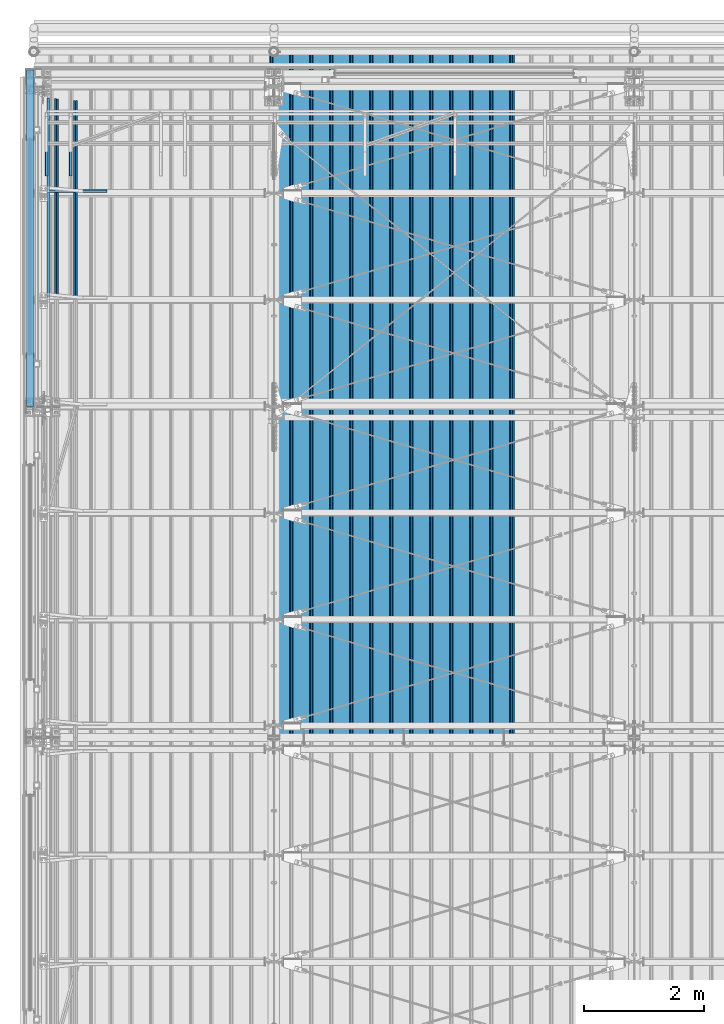
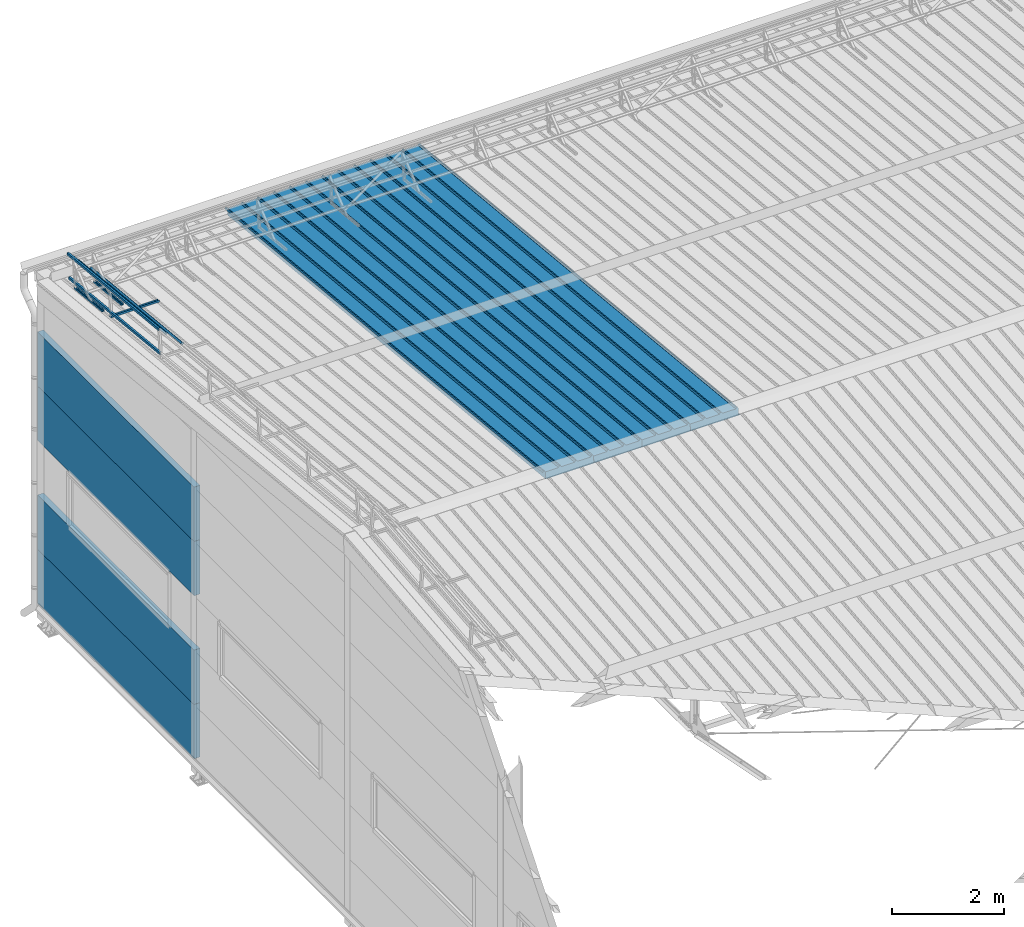
# One storey, part 50 of 709: 15 beams, 15 elements without a shape of their own.
"""IFC4 building model written with IfcOpenShell, lengths in millimetres."""

from ifc_helpers import new_model, si_unit, direction, frame, origin_with_axes, place, context, subcontext, project, spatial, line, indexed_curve, outline, extrude, material, element, aggregate, save


model = new_model("IFC4")

# Units and contexts
model_context = context("Model", 3, precision=0.2, world=origin_with_axes(), true_north=direction((0.0, 1.0)))
body_context = subcontext(model_context, "Body", "Model", "MODEL_VIEW")
ifc_project = project(units=[si_unit("LENGTHUNIT", "METRE", prefix="MILLI"), si_unit("AREAUNIT", "SQUARE_METRE"), si_unit("VOLUMEUNIT", "CUBIC_METRE"), si_unit("MASSUNIT", "GRAM", prefix="KILO"), si_unit("TIMEUNIT", "SECOND"), si_unit("PLANEANGLEUNIT", "RADIAN"), si_unit("SOLIDANGLEUNIT", "STERADIAN"), si_unit("THERMODYNAMICTEMPERATUREUNIT", "DEGREE_CELSIUS"), si_unit("LUMINOUSINTENSITYUNIT", "LUMEN")], contexts=[model_context])

# Site, building, storey
site_placement = place(None, origin_with_axes())
site = spatial("IfcSite", under=ifc_project, at=site_placement, CompositionType="ELEMENT")
building_placement = place(site_placement, origin_with_axes())
building = spatial("IfcBuilding", under=site, at=building_placement, Name="Undefined", CompositionType="ELEMENT")
storey_placement = place(building_placement, origin_with_axes())
storey = spatial("IfcBuildingStorey", under=building, at=storey_placement, Name="Undefined", CompositionType="ELEMENT", Elevation=0.0)

# Assembly, beam
assembly_1_placement = place(storey_placement, frame((7452.44, 11009.10459, 8419.96887), z_axis=(1.0, 0.0, 0.0), x_axis=(0.0, 0.9950371902, -0.099503719)))
assembly_1 = element("IfcElementAssembly", 1, at=assembly_1_placement, inside=storey)
ifc_material_1 = material(Name="Insulation", Category="Insulation")
beam_1_placement = place(assembly_1_placement, origin_with_axes())
beam_1 = element("IfcBeam", 2, at=beam_1_placement, material=ifc_material_1, ObjectType="P-99", context=body_context, shape_type="SolidModel", body=[
    extrude(outline(indexed_curve([(-509.8453, 89.5), (-490.1547, 89.5), (-471.67949, 57.5), (-471.67949, -88.5), (-436.67949, -88.5), (-436.67949, -91.5), (562.55841, -91.5), (562.55841, -89.5), (527.55841, -89.5), (527.55841, 57.5), (510.2379, 88.5), (489.7621, 88.5), (472.44159, 58.5), (196.71923, 58.5), (177.66667, 91.5), (155.66667, 91.5), (136.61411, 58.5), (-136.61411, 58.5), (-155.66667, 91.5), (-177.66667, 91.5), (-196.71923, 58.5), (-469.94744, 58.5), (-489.0, 91.5), (-511.0, 91.5), (-527.16581, 63.5), (-525.43376, 62.5)], segments=[line(1, 2, 3, 4, 5, 6, 7, 8, 9, 10, 11, 12, 13, 14, 15, 16, 17, 18, 19, 20, 21, 22, 23, 24, 25, 26, 1)])), frame((0.0, 0.0, 0.0), z_axis=(-1.0, 0.0, 0.0), x_axis=(0.0, 0.0, 1.0)), (0.0, 0.0, -1.0), 11459.0),
])
aggregate(assembly_1, [beam_1])

assembly_2_placement = place(storey_placement, frame((6452.44, 11009.10459, 8419.96887), z_axis=(1.0, 0.0, 0.0), x_axis=(0.0, 0.9950371902, -0.099503719)))
assembly_2 = element("IfcElementAssembly", 3, at=assembly_2_placement, inside=storey)
beam_2_placement = place(assembly_2_placement, origin_with_axes())
beam_2 = element("IfcBeam", 4, at=beam_2_placement, material=ifc_material_1, ObjectType="P-99", context=body_context, shape_type="SolidModel", body=[
    extrude(outline(indexed_curve([(-509.8453, 89.5), (-490.1547, 89.5), (-471.67949, 57.5), (-471.67949, -88.5), (-436.67949, -88.5), (-436.67949, -91.5), (562.55841, -91.5), (562.55841, -89.5), (527.55841, -89.5), (527.55841, 57.5), (510.2379, 88.5), (489.7621, 88.5), (472.44159, 58.5), (196.71923, 58.5), (177.66667, 91.5), (155.66667, 91.5), (136.61411, 58.5), (-136.61411, 58.5), (-155.66667, 91.5), (-177.66667, 91.5), (-196.71923, 58.5), (-469.94744, 58.5), (-489.0, 91.5), (-511.0, 91.5), (-527.16581, 63.5), (-525.43376, 62.5)], segments=[line(1, 2, 3, 4, 5, 6, 7, 8, 9, 10, 11, 12, 13, 14, 15, 16, 17, 18, 19, 20, 21, 22, 23, 24, 25, 26, 1)])), frame((0.0, 0.0, 0.0), z_axis=(-1.0, 0.0, 0.0), x_axis=(0.0, 0.0, 1.0)), (0.0, 0.0, -1.0), 11459.0),
])
aggregate(assembly_2, [beam_2])

assembly_3_placement = place(storey_placement, frame((5452.44, 11009.10459, 8419.96887), z_axis=(1.0, 0.0, 0.0), x_axis=(0.0, 0.9950371902, -0.099503719)))
assembly_3 = element("IfcElementAssembly", 5, at=assembly_3_placement, inside=storey)
beam_3_placement = place(assembly_3_placement, origin_with_axes())
beam_3 = element("IfcBeam", 6, at=beam_3_placement, material=ifc_material_1, ObjectType="P-99", context=body_context, shape_type="SolidModel", body=[
    extrude(outline(indexed_curve([(-509.8453, 89.5), (-490.1547, 89.5), (-471.67949, 57.5), (-471.67949, -88.5), (-436.67949, -88.5), (-436.67949, -91.5), (562.55841, -91.5), (562.55841, -89.5), (527.55841, -89.5), (527.55841, 57.5), (510.2379, 88.5), (489.7621, 88.5), (472.44159, 58.5), (196.71923, 58.5), (177.66667, 91.5), (155.66667, 91.5), (136.61411, 58.5), (-136.61411, 58.5), (-155.66667, 91.5), (-177.66667, 91.5), (-196.71923, 58.5), (-469.94744, 58.5), (-489.0, 91.5), (-511.0, 91.5), (-527.16581, 63.5), (-525.43376, 62.5)], segments=[line(1, 2, 3, 4, 5, 6, 7, 8, 9, 10, 11, 12, 13, 14, 15, 16, 17, 18, 19, 20, 21, 22, 23, 24, 25, 26, 1)])), frame((0.0, 0.0, 0.0), z_axis=(-1.0, 0.0, 0.0), x_axis=(0.0, 0.0, 1.0)), (0.0, 0.0, -1.0), 11459.0),
])
aggregate(assembly_3, [beam_3])

assembly_4_placement = place(storey_placement, frame((4452.44, 11009.10459, 8419.96887), z_axis=(1.0, 0.0, 0.0), x_axis=(0.0, 0.9950371902, -0.099503719)))
assembly_4 = element("IfcElementAssembly", 7, at=assembly_4_placement, inside=storey)
beam_4_placement = place(assembly_4_placement, origin_with_axes())
beam_4 = element("IfcBeam", 8, at=beam_4_placement, material=ifc_material_1, ObjectType="P-99", context=body_context, shape_type="SolidModel", body=[
    extrude(outline(indexed_curve([(-509.8453, 89.5), (-490.1547, 89.5), (-471.67949, 57.5), (-471.67949, -88.5), (-436.67949, -88.5), (-436.67949, -91.5), (562.55841, -91.5), (562.55841, -89.5), (527.55841, -89.5), (527.55841, 57.5), (510.2379, 88.5), (489.7621, 88.5), (472.44159, 58.5), (196.71923, 58.5), (177.66667, 91.5), (155.66667, 91.5), (136.61411, 58.5), (-136.61411, 58.5), (-155.66667, 91.5), (-177.66667, 91.5), (-196.71923, 58.5), (-469.94744, 58.5), (-489.0, 91.5), (-511.0, 91.5), (-527.16581, 63.5), (-525.43376, 62.5)], segments=[line(1, 2, 3, 4, 5, 6, 7, 8, 9, 10, 11, 12, 13, 14, 15, 16, 17, 18, 19, 20, 21, 22, 23, 24, 25, 26, 1)])), frame((0.0, 0.0, 0.0), z_axis=(-1.0, 0.0, 0.0), x_axis=(0.0, 0.0, 1.0)), (0.0, 0.0, -1.0), 11459.0),
])
aggregate(assembly_4, [beam_4])

assembly_5_placement = place(storey_placement, frame((615.0, 21349.29926, 7565.33969), z_axis=(0.0, 0.099503719, 0.9950371902), x_axis=(0.0, -0.9950371902, 0.099503719)))
assembly_5 = element("IfcElementAssembly", 9, at=assembly_5_placement, inside=storey)
ifc_material_2 = material(Name="Steel_Undefined", Category="STEEL")
beam_5_placement = place(assembly_5_placement, origin_with_axes())
beam_5 = element("IfcBeam", 10, at=beam_5_placement, material=ifc_material_2, ObjectType="601", context=body_context, shape_type="SolidModel", body=[
    extrude(outline(indexed_curve([(-20.0, -25.0), (20.0, -25.0), (20.0, -22.5), (-17.5, -22.5), (-17.5, 22.5), (20.0, 22.5), (20.0, 25.0), (-20.0, 25.0)], segments=[line(1, 2, 3, 4, 5, 6, 7, 8, 1)])), frame((0.0, 0.0, 0.0), z_axis=(-1.0, 0.0, 0.0), x_axis=(0.0, 0.0, 1.0)), (0.0, 0.0, -1.0), 1000.0),
])
aggregate(assembly_5, [beam_5])

assembly_6_placement = place(storey_placement, frame((215.0, 21349.29926, 7565.33969), z_axis=(0.0, 0.099503719, 0.9950371902), x_axis=(0.0, -0.9950371902, 0.099503719)))
assembly_6 = element("IfcElementAssembly", 11, at=assembly_6_placement, inside=storey)
beam_6_placement = place(assembly_6_placement, origin_with_axes())
beam_6 = element("IfcBeam", 12, at=beam_6_placement, material=ifc_material_2, ObjectType="601", context=body_context, shape_type="SolidModel", body=[
    extrude(outline(indexed_curve([(-20.0, -25.0), (20.0, -25.0), (20.0, -22.5), (-17.5, -22.5), (-17.5, 22.5), (20.0, 22.5), (20.0, 25.0), (-20.0, 25.0)], segments=[line(1, 2, 3, 4, 5, 6, 7, 8, 1)])), frame((0.0, 0.0, 0.0), z_axis=(-1.0, 0.0, 0.0), x_axis=(0.0, 0.0, 1.0)), (0.0, 0.0, -1.0), 1000.0),
])
aggregate(assembly_6, [beam_6])

assembly_7_placement = place(storey_placement, frame((220.0, 20100.16625, 7690.25299), z_axis=(0.0, 0.099503719, 0.9950371902), x_axis=(1.0, 0.0, 0.0)))
assembly_7 = element("IfcElementAssembly", 13, at=assembly_7_placement, inside=storey)
beam_7_placement = place(assembly_7_placement, origin_with_axes())
beam_7 = element("IfcBeam", 14, at=beam_7_placement, material=ifc_material_2, ObjectType="601", context=body_context, shape_type="SolidModel", body=[
    extrude(outline(indexed_curve([(-20.0, -25.0), (20.0, -25.0), (20.0, -22.5), (-17.5, -22.5), (-17.5, 22.5), (20.0, 22.5), (20.0, 25.0), (-20.0, 25.0)], segments=[line(1, 2, 3, 4, 5, 6, 7, 8, 1)])), frame((0.0, 0.0, 0.0), z_axis=(-1.0, 0.0, 0.0), x_axis=(0.0, 0.0, 1.0)), (0.0, 0.0, -1.0), 1000.0),
])
aggregate(assembly_7, [beam_7])

assembly_8_placement = place(storey_placement, frame((240.0, 18381.17866, 8445.04453), z_axis=(1.0, 0.0, 0.0), x_axis=(0.0, 0.9950371902, -0.099503719)))
assembly_8 = element("IfcElementAssembly", 15, at=assembly_8_placement, inside=storey)
beam_8_placement = place(assembly_8_placement, origin_with_axes())
beam_8 = element("IfcBeam", 16, at=beam_8_placement, material=ifc_material_2, ObjectType="608", context=body_context, shape_type="SolidModel", body=[
    extrude(outline(indexed_curve([(-20.0, -25.0), (20.0, -25.0), (20.0, -22.5), (-17.5, -22.5), (-17.5, 22.5), (20.0, 22.5), (20.0, 25.0), (-20.0, 25.0)], segments=[line(1, 2, 3, 4, 5, 6, 7, 8, 1)])), frame((0.0, 0.0, 0.0), z_axis=(-1.0, 0.0, 0.0), x_axis=(0.0, 0.0, 1.0)), (0.0, 0.0, -1.0), 3285.56115),
])
aggregate(assembly_8, [beam_8])

assembly_9_placement = place(storey_placement, frame((240.0, 18331.4268, 7947.52594), z_axis=(1.0, 0.0, 0.0), x_axis=(0.0, 0.9950371902, -0.099503719)))
assembly_9 = element("IfcElementAssembly", 17, at=assembly_9_placement, inside=storey)
beam_9_placement = place(assembly_9_placement, origin_with_axes())
beam_9 = element("IfcBeam", 18, at=beam_9_placement, material=ifc_material_2, ObjectType="608", context=body_context, shape_type="SolidModel", body=[
    extrude(outline(indexed_curve([(-20.0, -25.0), (20.0, -25.0), (20.0, -22.5), (-17.5, -22.5), (-17.5, 22.5), (20.0, 22.5), (20.0, 25.0), (-20.0, 25.0)], segments=[line(1, 2, 3, 4, 5, 6, 7, 8, 1)])), frame((0.0, 0.0, 0.0), z_axis=(-1.0, 0.0, 0.0), x_axis=(0.0, 0.0, 1.0)), (0.0, 0.0, -1.0), 3285.56115),
])
aggregate(assembly_9, [beam_9])

assembly_10_placement = place(storey_placement, frame((375.56349, 18368.5139, 8318.39698), z_axis=(0.707106781, 0.070359754, 0.703597545), x_axis=(0.0, 0.9950371902, -0.099503719)))
assembly_10 = element("IfcElementAssembly", 19, at=assembly_10_placement, inside=storey)
beam_10_placement = place(assembly_10_placement, origin_with_axes())
beam_10 = element("IfcBeam", 20, at=beam_10_placement, material=ifc_material_2, ObjectType="608", context=body_context, shape_type="SolidModel", body=[
    extrude(outline(indexed_curve([(-20.0, -25.0), (20.0, -25.0), (20.0, -22.5), (-17.5, -22.5), (-17.5, 22.5), (20.0, 22.5), (20.0, 25.0), (-20.0, 25.0)], segments=[line(1, 2, 3, 4, 5, 6, 7, 8, 1)])), frame((0.0, 0.0, 0.0), z_axis=(-1.0, 0.0, 0.0), x_axis=(0.0, 0.0, 1.0)), (0.0, 0.0, -1.0), 3285.56115),
])
aggregate(assembly_10, [beam_10])

assembly_11_placement = place(storey_placement, frame((692.72078, 18336.95557, 8002.81368), z_axis=(0.707106781, 0.070359754, 0.703597545), x_axis=(0.0, 0.9950371902, -0.099503719)))
assembly_11 = element("IfcElementAssembly", 21, at=assembly_11_placement, inside=storey)
beam_11_placement = place(assembly_11_placement, origin_with_axes())
beam_11 = element("IfcBeam", 22, at=beam_11_placement, material=ifc_material_2, ObjectType="608", context=body_context, shape_type="SolidModel", body=[
    extrude(outline(indexed_curve([(-20.0, -25.0), (20.0, -25.0), (20.0, -22.5), (-17.5, -22.5), (-17.5, 22.5), (20.0, 22.5), (20.0, 25.0), (-20.0, 25.0)], segments=[line(1, 2, 3, 4, 5, 6, 7, 8, 1)])), frame((0.0, 0.0, 0.0), z_axis=(-1.0, 0.0, 0.0), x_axis=(0.0, 0.0, 1.0)), (0.0, 0.0, -1.0), 3285.56115),
])
aggregate(assembly_11, [beam_11])

assembly_12_placement = place(storey_placement, frame((-60.0, 16510.0, 895.0), z_axis=(0.0, 0.0, -1.0), x_axis=(0.0, 1.0, 0.0)))
assembly_12 = element("IfcElementAssembly", 23, at=assembly_12_placement, inside=storey)
beam_12_placement = place(assembly_12_placement, origin_with_axes())
beam_12 = element("IfcBeam", 24, at=beam_12_placement, material=ifc_material_1, ObjectType="P-130", context=body_context, shape_type="SolidModel", body=[
    extrude(outline(indexed_curve([(-595.0, -60.0), (595.0, -60.0), (595.0, 60.0), (-595.0, 60.0)], segments=[line(1, 2, 3, 4, 1)])), frame((0.0, 0.0, 0.0), z_axis=(-1.0, 0.0, 0.0), x_axis=(0.0, 0.0, 1.0)), (0.0, 0.0, -1.0), 5610.0),
])
aggregate(assembly_12, [beam_12])

assembly_13_placement = place(storey_placement, frame((-60.0, 16510.0, 2085.0), z_axis=(0.0, 0.0, -1.0), x_axis=(0.0, 1.0, 0.0)))
assembly_13 = element("IfcElementAssembly", 25, at=assembly_13_placement, inside=storey)
beam_13_placement = place(assembly_13_placement, origin_with_axes())
beam_13 = element("IfcBeam", 26, at=beam_13_placement, material=ifc_material_1, ObjectType="P-130", context=body_context, shape_type="SolidModel", body=[
    extrude(outline(indexed_curve([(-595.0, -60.0), (595.0, -60.0), (595.0, 60.0), (-595.0, 60.0)], segments=[line(1, 2, 3, 4, 1)])), frame((0.0, 0.0, 0.0), z_axis=(-1.0, 0.0, 0.0), x_axis=(0.0, 0.0, 1.0)), (0.0, 0.0, -1.0), 5610.0),
])
aggregate(assembly_13, [beam_13])

assembly_14_placement = place(storey_placement, frame((-60.0, 16510.0, 4465.0), z_axis=(0.0, 0.0, -1.0), x_axis=(0.0, 1.0, 0.0)))
assembly_14 = element("IfcElementAssembly", 27, at=assembly_14_placement, inside=storey)
beam_14_placement = place(assembly_14_placement, origin_with_axes())
beam_14 = element("IfcBeam", 28, at=beam_14_placement, material=ifc_material_1, ObjectType="P-130", context=body_context, shape_type="SolidModel", body=[
    extrude(outline(indexed_curve([(-595.0, -60.0), (595.0, -60.0), (595.0, 60.0), (-595.0, 60.0)], segments=[line(1, 2, 3, 4, 1)])), frame((0.0, 0.0, 0.0), z_axis=(-1.0, 0.0, 0.0), x_axis=(0.0, 0.0, 1.0)), (0.0, 0.0, -1.0), 5610.0),
])
aggregate(assembly_14, [beam_14])

assembly_15_placement = place(storey_placement, frame((-60.0, 16510.0, 5655.0), z_axis=(0.0, 0.0, -1.0), x_axis=(0.0, 1.0, 0.0)))
assembly_15 = element("IfcElementAssembly", 29, at=assembly_15_placement, inside=storey)
beam_15_placement = place(assembly_15_placement, origin_with_axes())
beam_15 = element("IfcBeam", 30, at=beam_15_placement, material=ifc_material_1, ObjectType="P-130", context=body_context, shape_type="SolidModel", body=[
    extrude(outline(indexed_curve([(-595.0, -60.0), (595.0, -60.0), (595.0, 60.0), (-595.0, 60.0)], segments=[line(1, 2, 3, 4, 1)])), frame((0.0, 0.0, 0.0), z_axis=(-1.0, 0.0, 0.0), x_axis=(0.0, 0.0, 1.0)), (0.0, 0.0, -1.0), 5610.0),
])
aggregate(assembly_15, [beam_15])

save(model, "model.ifc")
